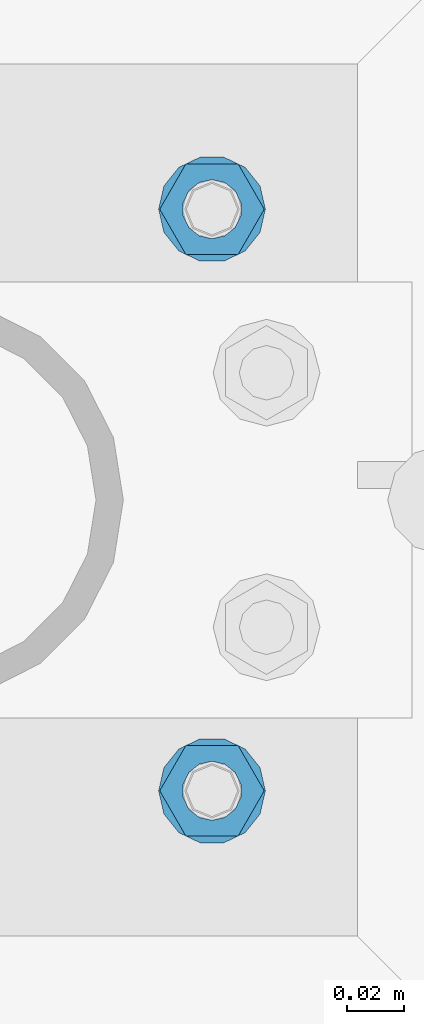
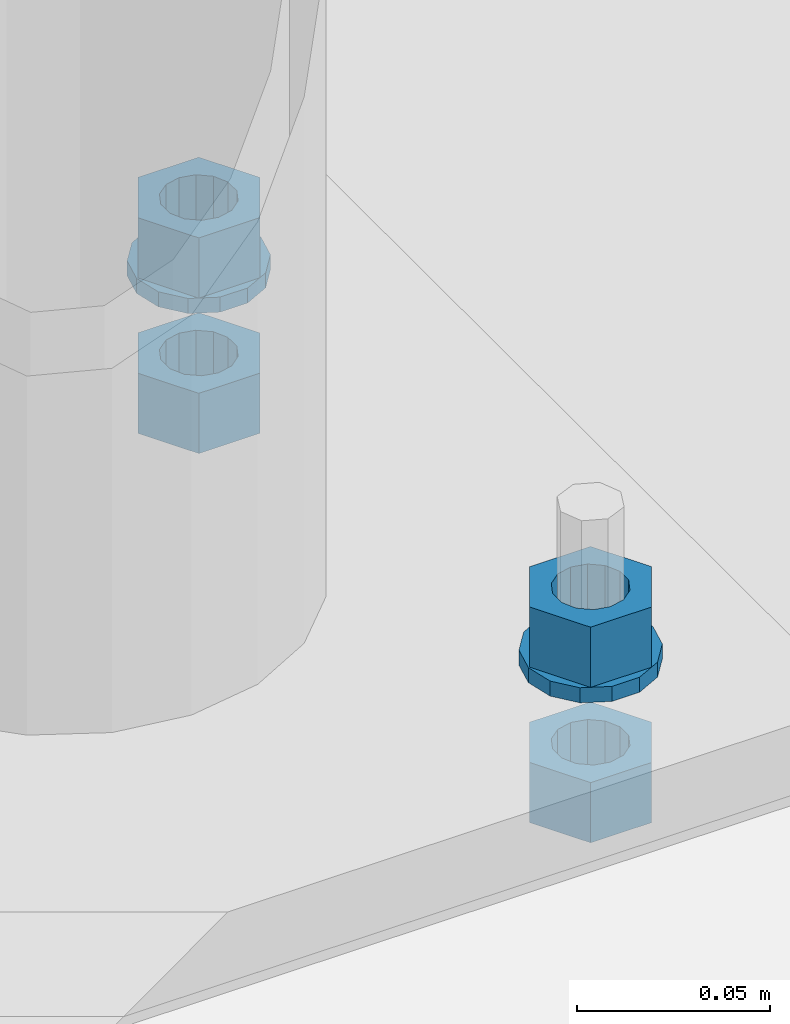
# One storey, part 585 of 975: 6 beams.
"""IFC2X3 building model written with IfcOpenShell, lengths in millimetres."""

from ifc_helpers import new_model, si_unit, frame, origin_with_axes, place, context, subcontext, project, spatial, faceted_brep, material, type_object, element, save


model = new_model("IFC2X3")

# Units and contexts
model_context = context("Model", 3, precision=1e-05, world=origin_with_axes())
body_context = subcontext(model_context, "Body", "Model", "MODEL_VIEW")
ifc_project = project(units=[si_unit("LENGTHUNIT", "METRE", prefix="MILLI"), si_unit("AREAUNIT", "SQUARE_METRE"), si_unit("VOLUMEUNIT", "CUBIC_METRE"), si_unit("MASSUNIT", "GRAM", prefix="KILO"), si_unit("TIMEUNIT", "SECOND"), si_unit("PLANEANGLEUNIT", "RADIAN"), si_unit("SOLIDANGLEUNIT", "STERADIAN"), si_unit("THERMODYNAMICTEMPERATUREUNIT", "DEGREE_CELSIUS"), si_unit("LUMINOUSINTENSITYUNIT", "LUMEN")], contexts=[model_context])

# Site, building, storey
site_placement = place(None, origin_with_axes())
site = spatial("IfcSite", under=ifc_project, at=site_placement, CompositionType="ELEMENT")
building_placement = place(site_placement, origin_with_axes())
building = spatial("IfcBuilding", under=site, at=building_placement, Name="Undefined", CompositionType="ELEMENT")
storey_placement = place(building_placement, origin_with_axes())
storey = spatial("IfcBuildingStorey", under=building, at=storey_placement, Name="Undefined", CompositionType="ELEMENT", Elevation=0.0)

# Beams
ifc_material = material(Name="STEEL/A36")
beam_type_1 = type_object("IfcBeamType", Name="3/4_WASHER", PredefinedType="NOTDEFINED")
beam_1_placement = place(storey_placement, frame((24826.9124984741, 13290.5500030518, -236.537499999998), z_axis=(0.0, -1.0, 0.0), x_axis=(0.0, 0.0, -1.0)))
element("IfcBeam", 1, at=beam_1_placement, inside=storey, type_object=beam_type_1, material=ifc_material, Name="WASHER", ObjectType="3/4_WASHER", context=body_context, shape_type="Brep", body=[
    faceted_brep([(0.0, -18.6499996185303, 0.0), (0.0, -16.8030690426876, -8.09193156902904), (4.76250000000073, -16.8030690426876, -8.09193156902904), (4.76250000000073, -18.6499996185303, 0.0), (0.0, -11.6280845668225, -14.5811568497838), (4.76250000000073, -11.6280845668225, -14.5811568497838), (0.0, -4.15001533340001, -18.1824051902857), (4.76250000000073, -4.15001533340001, -18.1824051902857), (0.0, 4.15001533340001, -18.1824051902857), (4.76250000000073, 4.15001533340001, -18.1824051902857), (0.0, 11.6280845668234, -14.5811568497838), (4.76250000000073, 11.6280845668234, -14.5811568497838), (0.0, 16.8030690426876, -8.09193156902904), (4.76250000000073, 16.8030690426876, -8.09193156902904), (0.0, 18.6499996185303, 0.0), (4.76250000000073, 18.6499996185303, 0.0), (0.0, 16.8030690426876, 8.09193156902904), (4.76250000000073, 16.8030690426876, 8.09193156902904), (0.0, 11.6280845668225, 14.5811568497838), (4.76250000000073, 11.6280845668225, 14.5811568497838), (0.0, 4.15001533340001, 18.1824051902857), (4.76250000000073, 4.15001533340001, 18.1824051902857), (0.0, -4.15001533340001, 18.1824051902857), (4.76250000000073, -4.15001533340001, 18.1824051902857), (0.0, -11.6280845668234, 14.5811568497838), (4.76250000000073, -11.6280845668234, 14.5811568497838), (0.0, -16.8030690426876, 8.09193156902904), (4.76250000000073, -16.8030690426876, 8.09193156902904), (0.0, 0.0, 10.3199996948242), (0.0, 4.47768005528269, 9.29799844179911), (4.76250000000073, 4.47768005528269, 9.29799844179911), (4.76250000000073, 0.0, 10.3199996948242), (0.0, 8.06850066047446, 6.43441456490817), (4.76250000000073, 8.06850066047446, 6.43441456490817), (0.0, 10.0612557561917, 2.29641597052117), (4.76250000000073, 10.0612557561917, 2.29641597052117), (0.0, 10.0612557561917, -2.29641597052117), (4.76250000000073, 10.0612557561917, -2.29641597052117), (0.0, 8.06850066047446, -6.43441456490814), (4.76250000000073, 8.06850066047446, -6.43441456490814), (0.0, 4.47768005528269, -9.29799844179908), (4.76250000000073, 4.47768005528269, -9.29799844179908), (0.0, 0.0, -10.3199996948242), (4.76250000000073, 0.0, -10.3199996948242), (0.0, -4.47768005528269, -9.29799844179911), (4.76250000000073, -4.47768005528269, -9.29799844179911), (0.0, -8.06850066047446, -6.43441456490817), (4.76250000000073, -8.06850066047446, -6.43441456490817), (0.0, -10.0612557561917, -2.29641597052117), (4.76250000000073, -10.0612557561917, -2.29641597052117), (0.0, -10.0612557561917, 2.29641597052117), (4.76250000000073, -10.0612557561917, 2.29641597052117), (0.0, -8.06850066047446, 6.43441456490814), (4.76250000000073, -8.06850066047446, 6.43441456490814), (0.0, -4.47768005528269, 9.29799844179908), (4.76250000000073, -4.47768005528269, 9.29799844179908)], [[[0, 1, 2, 3]], [[1, 4, 5, 2]], [[4, 6, 7, 5]], [[6, 8, 9, 7]], [[8, 10, 11, 9]], [[10, 12, 13, 11]], [[12, 14, 15, 13]], [[14, 16, 17, 15]], [[16, 18, 19, 17]], [[18, 20, 21, 19]], [[20, 22, 23, 21]], [[22, 24, 25, 23]], [[24, 26, 27, 25]], [[26, 0, 3, 27]], [[28, 29, 30, 31]], [[29, 32, 33, 30]], [[32, 34, 35, 33]], [[34, 36, 37, 35]], [[36, 38, 39, 37]], [[38, 40, 41, 39]], [[40, 42, 43, 41]], [[42, 44, 45, 43]], [[44, 46, 47, 45]], [[46, 48, 49, 47]], [[48, 50, 51, 49]], [[50, 52, 53, 51]], [[52, 54, 55, 53]], [[54, 28, 31, 55]], [[5, 7, 9, 11, 13, 15, 17, 19, 21, 23, 25, 27, 3, 2], [33, 35, 37, 39, 41, 43, 45, 47, 49, 51, 53, 55, 31, 30]], [[26, 24, 22, 20, 18, 16, 14, 12, 10, 8, 6, 4, 1, 0], [54, 52, 50, 48, 46, 44, 42, 40, 38, 36, 34, 32, 29, 28]]]),
])
beam_2_placement = place(storey_placement, frame((24826.9124984741, 13493.75, -236.537499999998), z_axis=(0.0, -1.0, 0.0), x_axis=(0.0, 0.0, -1.0)))
element("IfcBeam", 2, at=beam_2_placement, inside=storey, type_object=beam_type_1, material=ifc_material, Name="WASHER", ObjectType="3/4_WASHER", context=body_context, shape_type="Brep", body=[
    faceted_brep([(0.0, -18.6499996185303, 0.0), (0.0, -16.8030690426876, -8.09193156902904), (4.76250000000073, -16.8030690426876, -8.09193156902904), (4.76250000000073, -18.6499996185303, 0.0), (0.0, -11.6280845668225, -14.5811568497838), (4.76250000000073, -11.6280845668225, -14.5811568497838), (0.0, -4.15001533340001, -18.1824051902857), (4.76250000000073, -4.15001533340001, -18.1824051902857), (0.0, 4.15001533340001, -18.1824051902857), (4.76250000000073, 4.15001533340001, -18.1824051902857), (0.0, 11.6280845668234, -14.5811568497838), (4.76250000000073, 11.6280845668234, -14.5811568497838), (0.0, 16.8030690426876, -8.09193156902904), (4.76250000000073, 16.8030690426876, -8.09193156902904), (0.0, 18.6499996185303, 0.0), (4.76250000000073, 18.6499996185303, 0.0), (0.0, 16.8030690426876, 8.09193156902904), (4.76250000000073, 16.8030690426876, 8.09193156902904), (0.0, 11.6280845668225, 14.5811568497838), (4.76250000000073, 11.6280845668225, 14.5811568497838), (0.0, 4.15001533340001, 18.1824051902857), (4.76250000000073, 4.15001533340001, 18.1824051902857), (0.0, -4.15001533340001, 18.1824051902857), (4.76250000000073, -4.15001533340001, 18.1824051902857), (0.0, -11.6280845668234, 14.5811568497838), (4.76250000000073, -11.6280845668234, 14.5811568497838), (0.0, -16.8030690426876, 8.09193156902904), (4.76250000000073, -16.8030690426876, 8.09193156902904), (0.0, 0.0, 10.3199996948242), (0.0, 4.47768005528269, 9.29799844179911), (4.76250000000073, 4.47768005528269, 9.29799844179911), (4.76250000000073, 0.0, 10.3199996948242), (0.0, 8.06850066047446, 6.43441456490817), (4.76250000000073, 8.06850066047446, 6.43441456490817), (0.0, 10.0612557561917, 2.29641597052117), (4.76250000000073, 10.0612557561917, 2.29641597052117), (0.0, 10.0612557561917, -2.29641597052117), (4.76250000000073, 10.0612557561917, -2.29641597052117), (0.0, 8.06850066047446, -6.43441456490814), (4.76250000000073, 8.06850066047446, -6.43441456490814), (0.0, 4.47768005528269, -9.29799844179908), (4.76250000000073, 4.47768005528269, -9.29799844179908), (0.0, 0.0, -10.3199996948242), (4.76250000000073, 0.0, -10.3199996948242), (0.0, -4.47768005528269, -9.29799844179911), (4.76250000000073, -4.47768005528269, -9.29799844179911), (0.0, -8.06850066047446, -6.43441456490817), (4.76250000000073, -8.06850066047446, -6.43441456490817), (0.0, -10.0612557561917, -2.29641597052117), (4.76250000000073, -10.0612557561917, -2.29641597052117), (0.0, -10.0612557561917, 2.29641597052117), (4.76250000000073, -10.0612557561917, 2.29641597052117), (0.0, -8.06850066047446, 6.43441456490814), (4.76250000000073, -8.06850066047446, 6.43441456490814), (0.0, -4.47768005528269, 9.29799844179908), (4.76250000000073, -4.47768005528269, 9.29799844179908)], [[[0, 1, 2, 3]], [[1, 4, 5, 2]], [[4, 6, 7, 5]], [[6, 8, 9, 7]], [[8, 10, 11, 9]], [[10, 12, 13, 11]], [[12, 14, 15, 13]], [[14, 16, 17, 15]], [[16, 18, 19, 17]], [[18, 20, 21, 19]], [[20, 22, 23, 21]], [[22, 24, 25, 23]], [[24, 26, 27, 25]], [[26, 0, 3, 27]], [[28, 29, 30, 31]], [[29, 32, 33, 30]], [[32, 34, 35, 33]], [[34, 36, 37, 35]], [[36, 38, 39, 37]], [[38, 40, 41, 39]], [[40, 42, 43, 41]], [[42, 44, 45, 43]], [[44, 46, 47, 45]], [[46, 48, 49, 47]], [[48, 50, 51, 49]], [[50, 52, 53, 51]], [[52, 54, 55, 53]], [[54, 28, 31, 55]], [[5, 7, 9, 11, 13, 15, 17, 19, 21, 23, 25, 27, 3, 2], [33, 35, 37, 39, 41, 43, 45, 47, 49, 51, 53, 55, 31, 30]], [[26, 24, 22, 20, 18, 16, 14, 12, 10, 8, 6, 4, 1, 0], [54, 52, 50, 48, 46, 44, 42, 40, 38, 36, 34, 32, 29, 28]]]),
])
beam_type_2 = type_object("IfcBeamType", Name="3/4_HEAVY_HEX_NUT", PredefinedType="NOTDEFINED")
beam_3_placement = place(storey_placement, frame((24826.9124984741, 13290.5500030518, -217.487499999999), z_axis=(0.0, -1.0, 0.0), x_axis=(0.0, 0.0, -1.0)))
element("IfcBeam", 3, at=beam_3_placement, inside=storey, type_object=beam_type_2, material=ifc_material, Name="NUT", ObjectType="3/4_HEAVY_HEX_NUT", context=body_context, shape_type="Brep", body=[
    faceted_brep([(0.0, -18.2600002288818, 0.0), (0.0, -9.13000011444092, -15.8100004196167), (19.0499999999993, -9.13000011444092, -15.8100004196167), (19.0499999999993, -18.2600002288818, 0.0), (0.0, 9.13000011444092, -15.8100004196167), (19.0499999999993, 9.13000011444092, -15.8100004196167), (0.0, 18.2600002288818, 0.0), (19.0499999999993, 18.2600002288818, 0.0), (0.0, 9.13000011444092, 15.8100004196167), (19.0499999999993, 9.13000011444092, 15.8100004196167), (0.0, -9.13000011444092, 15.8100004196167), (19.0499999999993, -9.13000011444092, 15.8100004196167), (0.0, 0.0, 10.3199996948242), (0.0, 4.47768005528269, 9.29799844179911), (19.0499999999993, 4.47768005528269, 9.29799844179911), (19.0499999999993, 0.0, 10.3199996948242), (0.0, 8.06850066047446, 6.43441456490817), (19.0499999999993, 8.06850066047446, 6.43441456490817), (0.0, 10.0612557561917, 2.29641597052117), (19.0499999999993, 10.0612557561917, 2.29641597052117), (0.0, 10.0612557561917, -2.29641597052117), (19.0499999999993, 10.0612557561917, -2.29641597052117), (0.0, 8.06850066047446, -6.43441456490814), (19.0499999999993, 8.06850066047446, -6.43441456490814), (0.0, 4.47768005528269, -9.29799844179908), (19.0499999999993, 4.47768005528269, -9.29799844179908), (0.0, 0.0, -10.3199996948242), (19.0499999999993, 0.0, -10.3199996948242), (0.0, -4.47768005528269, -9.29799844179911), (19.0499999999993, -4.47768005528269, -9.29799844179911), (0.0, -8.06850066047446, -6.43441456490817), (19.0499999999993, -8.06850066047446, -6.43441456490817), (0.0, -10.0612557561917, -2.29641597052117), (19.0499999999993, -10.0612557561917, -2.29641597052117), (0.0, -10.0612557561917, 2.29641597052117), (19.0499999999993, -10.0612557561917, 2.29641597052117), (0.0, -8.06850066047446, 6.43441456490814), (19.0499999999993, -8.06850066047446, 6.43441456490814), (0.0, -4.47768005528269, 9.29799844179908), (19.0499999999993, -4.47768005528269, 9.29799844179908)], [[[0, 1, 2, 3]], [[1, 4, 5, 2]], [[4, 6, 7, 5]], [[6, 8, 9, 7]], [[8, 10, 11, 9]], [[10, 0, 3, 11]], [[12, 13, 14, 15]], [[13, 16, 17, 14]], [[16, 18, 19, 17]], [[18, 20, 21, 19]], [[20, 22, 23, 21]], [[22, 24, 25, 23]], [[24, 26, 27, 25]], [[26, 28, 29, 27]], [[28, 30, 31, 29]], [[30, 32, 33, 31]], [[32, 34, 35, 33]], [[34, 36, 37, 35]], [[36, 38, 39, 37]], [[38, 12, 15, 39]], [[5, 7, 9, 11, 3, 2], [17, 19, 21, 23, 25, 27, 29, 31, 33, 35, 37, 39, 15, 14]], [[10, 8, 6, 4, 1, 0], [38, 36, 34, 32, 30, 28, 26, 24, 22, 20, 18, 16, 13, 12]]]),
])
beam_4_placement = place(storey_placement, frame((24826.9124984741, 13493.75, -217.487499999999), z_axis=(0.0, -1.0, 0.0), x_axis=(0.0, 0.0, -1.0)))
element("IfcBeam", 4, at=beam_4_placement, inside=storey, type_object=beam_type_2, material=ifc_material, Name="NUT", ObjectType="3/4_HEAVY_HEX_NUT", context=body_context, shape_type="Brep", body=[
    faceted_brep([(0.0, -18.2600002288818, 0.0), (0.0, -9.13000011444092, -15.8100004196167), (19.0499999999993, -9.13000011444092, -15.8100004196167), (19.0499999999993, -18.2600002288818, 0.0), (0.0, 9.13000011444092, -15.8100004196167), (19.0499999999993, 9.13000011444092, -15.8100004196167), (0.0, 18.2600002288818, 0.0), (19.0499999999993, 18.2600002288818, 0.0), (0.0, 9.13000011444092, 15.8100004196167), (19.0499999999993, 9.13000011444092, 15.8100004196167), (0.0, -9.13000011444092, 15.8100004196167), (19.0499999999993, -9.13000011444092, 15.8100004196167), (0.0, 0.0, 10.3199996948242), (0.0, 4.47768005528269, 9.29799844179911), (19.0499999999993, 4.47768005528269, 9.29799844179911), (19.0499999999993, 0.0, 10.3199996948242), (0.0, 8.06850066047446, 6.43441456490817), (19.0499999999993, 8.06850066047446, 6.43441456490817), (0.0, 10.0612557561917, 2.29641597052117), (19.0499999999993, 10.0612557561917, 2.29641597052117), (0.0, 10.0612557561917, -2.29641597052117), (19.0499999999993, 10.0612557561917, -2.29641597052117), (0.0, 8.06850066047446, -6.43441456490814), (19.0499999999993, 8.06850066047446, -6.43441456490814), (0.0, 4.47768005528269, -9.29799844179908), (19.0499999999993, 4.47768005528269, -9.29799844179908), (0.0, 0.0, -10.3199996948242), (19.0499999999993, 0.0, -10.3199996948242), (0.0, -4.47768005528269, -9.29799844179911), (19.0499999999993, -4.47768005528269, -9.29799844179911), (0.0, -8.06850066047446, -6.43441456490817), (19.0499999999993, -8.06850066047446, -6.43441456490817), (0.0, -10.0612557561917, -2.29641597052117), (19.0499999999993, -10.0612557561917, -2.29641597052117), (0.0, -10.0612557561917, 2.29641597052117), (19.0499999999993, -10.0612557561917, 2.29641597052117), (0.0, -8.06850066047446, 6.43441456490814), (19.0499999999993, -8.06850066047446, 6.43441456490814), (0.0, -4.47768005528269, 9.29799844179908), (19.0499999999993, -4.47768005528269, 9.29799844179908)], [[[0, 1, 2, 3]], [[1, 4, 5, 2]], [[4, 6, 7, 5]], [[6, 8, 9, 7]], [[8, 10, 11, 9]], [[10, 0, 3, 11]], [[12, 13, 14, 15]], [[13, 16, 17, 14]], [[16, 18, 19, 17]], [[18, 20, 21, 19]], [[20, 22, 23, 21]], [[22, 24, 25, 23]], [[24, 26, 27, 25]], [[26, 28, 29, 27]], [[28, 30, 31, 29]], [[30, 32, 33, 31]], [[32, 34, 35, 33]], [[34, 36, 37, 35]], [[36, 38, 39, 37]], [[38, 12, 15, 39]], [[5, 7, 9, 11, 3, 2], [17, 19, 21, 23, 25, 27, 29, 31, 33, 35, 37, 39, 15, 14]], [[10, 8, 6, 4, 1, 0], [38, 36, 34, 32, 30, 28, 26, 24, 22, 20, 18, 16, 13, 12]]]),
])
beam_5_placement = place(storey_placement, frame((24826.9124984741, 13290.5500030518, -266.7), z_axis=(0.0, -1.0, 0.0), x_axis=(0.0, 0.0, -1.0)))
element("IfcBeam", 5, at=beam_5_placement, inside=storey, type_object=beam_type_2, material=ifc_material, Name="NUT", ObjectType="3/4_HEAVY_HEX_NUT", context=body_context, shape_type="Brep", body=[
    faceted_brep([(0.0, -18.2600002288818, 0.0), (0.0, -9.13000011444092, -15.8100004196167), (19.0499999999993, -9.13000011444092, -15.8100004196167), (19.0499999999993, -18.2600002288818, 0.0), (0.0, 9.13000011444092, -15.8100004196167), (19.0499999999993, 9.13000011444092, -15.8100004196167), (0.0, 18.2600002288818, 0.0), (19.0499999999993, 18.2600002288818, 0.0), (0.0, 9.13000011444092, 15.8100004196167), (19.0499999999993, 9.13000011444092, 15.8100004196167), (0.0, -9.13000011444092, 15.8100004196167), (19.0499999999993, -9.13000011444092, 15.8100004196167), (0.0, 0.0, 10.3199996948242), (0.0, 4.47768005528269, 9.29799844179911), (19.0499999999993, 4.47768005528269, 9.29799844179911), (19.0499999999993, 0.0, 10.3199996948242), (0.0, 8.06850066047446, 6.43441456490817), (19.0499999999993, 8.06850066047446, 6.43441456490817), (0.0, 10.0612557561917, 2.29641597052117), (19.0499999999993, 10.0612557561917, 2.29641597052117), (0.0, 10.0612557561917, -2.29641597052117), (19.0499999999993, 10.0612557561917, -2.29641597052117), (0.0, 8.06850066047446, -6.43441456490814), (19.0499999999993, 8.06850066047446, -6.43441456490814), (0.0, 4.47768005528269, -9.29799844179908), (19.0499999999993, 4.47768005528269, -9.29799844179908), (0.0, 0.0, -10.3199996948242), (19.0499999999993, 0.0, -10.3199996948242), (0.0, -4.47768005528269, -9.29799844179911), (19.0499999999993, -4.47768005528269, -9.29799844179911), (0.0, -8.06850066047446, -6.43441456490817), (19.0499999999993, -8.06850066047446, -6.43441456490817), (0.0, -10.0612557561917, -2.29641597052117), (19.0499999999993, -10.0612557561917, -2.29641597052117), (0.0, -10.0612557561917, 2.29641597052117), (19.0499999999993, -10.0612557561917, 2.29641597052117), (0.0, -8.06850066047446, 6.43441456490814), (19.0499999999993, -8.06850066047446, 6.43441456490814), (0.0, -4.47768005528269, 9.29799844179908), (19.0499999999993, -4.47768005528269, 9.29799844179908)], [[[0, 1, 2, 3]], [[1, 4, 5, 2]], [[4, 6, 7, 5]], [[6, 8, 9, 7]], [[8, 10, 11, 9]], [[10, 0, 3, 11]], [[12, 13, 14, 15]], [[13, 16, 17, 14]], [[16, 18, 19, 17]], [[18, 20, 21, 19]], [[20, 22, 23, 21]], [[22, 24, 25, 23]], [[24, 26, 27, 25]], [[26, 28, 29, 27]], [[28, 30, 31, 29]], [[30, 32, 33, 31]], [[32, 34, 35, 33]], [[34, 36, 37, 35]], [[36, 38, 39, 37]], [[38, 12, 15, 39]], [[5, 7, 9, 11, 3, 2], [17, 19, 21, 23, 25, 27, 29, 31, 33, 35, 37, 39, 15, 14]], [[10, 8, 6, 4, 1, 0], [38, 36, 34, 32, 30, 28, 26, 24, 22, 20, 18, 16, 13, 12]]]),
])
beam_6_placement = place(storey_placement, frame((24826.9124984741, 13493.75, -266.7), z_axis=(0.0, -1.0, 0.0), x_axis=(0.0, 0.0, -1.0)))
element("IfcBeam", 6, at=beam_6_placement, inside=storey, type_object=beam_type_2, material=ifc_material, Name="NUT", ObjectType="3/4_HEAVY_HEX_NUT", context=body_context, shape_type="Brep", body=[
    faceted_brep([(0.0, -18.2600002288818, 0.0), (0.0, -9.13000011444092, -15.8100004196167), (19.0499999999993, -9.13000011444092, -15.8100004196167), (19.0499999999993, -18.2600002288818, 0.0), (0.0, 9.13000011444092, -15.8100004196167), (19.0499999999993, 9.13000011444092, -15.8100004196167), (0.0, 18.2600002288818, 0.0), (19.0499999999993, 18.2600002288818, 0.0), (0.0, 9.13000011444092, 15.8100004196167), (19.0499999999993, 9.13000011444092, 15.8100004196167), (0.0, -9.13000011444092, 15.8100004196167), (19.0499999999993, -9.13000011444092, 15.8100004196167), (0.0, 0.0, 10.3199996948242), (0.0, 4.47768005528269, 9.29799844179911), (19.0499999999993, 4.47768005528269, 9.29799844179911), (19.0499999999993, 0.0, 10.3199996948242), (0.0, 8.06850066047446, 6.43441456490817), (19.0499999999993, 8.06850066047446, 6.43441456490817), (0.0, 10.0612557561917, 2.29641597052117), (19.0499999999993, 10.0612557561917, 2.29641597052117), (0.0, 10.0612557561917, -2.29641597052117), (19.0499999999993, 10.0612557561917, -2.29641597052117), (0.0, 8.06850066047446, -6.43441456490814), (19.0499999999993, 8.06850066047446, -6.43441456490814), (0.0, 4.47768005528269, -9.29799844179908), (19.0499999999993, 4.47768005528269, -9.29799844179908), (0.0, 0.0, -10.3199996948242), (19.0499999999993, 0.0, -10.3199996948242), (0.0, -4.47768005528269, -9.29799844179911), (19.0499999999993, -4.47768005528269, -9.29799844179911), (0.0, -8.06850066047446, -6.43441456490817), (19.0499999999993, -8.06850066047446, -6.43441456490817), (0.0, -10.0612557561917, -2.29641597052117), (19.0499999999993, -10.0612557561917, -2.29641597052117), (0.0, -10.0612557561917, 2.29641597052117), (19.0499999999993, -10.0612557561917, 2.29641597052117), (0.0, -8.06850066047446, 6.43441456490814), (19.0499999999993, -8.06850066047446, 6.43441456490814), (0.0, -4.47768005528269, 9.29799844179908), (19.0499999999993, -4.47768005528269, 9.29799844179908)], [[[0, 1, 2, 3]], [[1, 4, 5, 2]], [[4, 6, 7, 5]], [[6, 8, 9, 7]], [[8, 10, 11, 9]], [[10, 0, 3, 11]], [[12, 13, 14, 15]], [[13, 16, 17, 14]], [[16, 18, 19, 17]], [[18, 20, 21, 19]], [[20, 22, 23, 21]], [[22, 24, 25, 23]], [[24, 26, 27, 25]], [[26, 28, 29, 27]], [[28, 30, 31, 29]], [[30, 32, 33, 31]], [[32, 34, 35, 33]], [[34, 36, 37, 35]], [[36, 38, 39, 37]], [[38, 12, 15, 39]], [[5, 7, 9, 11, 3, 2], [17, 19, 21, 23, 25, 27, 29, 31, 33, 35, 37, 39, 15, 14]], [[10, 8, 6, 4, 1, 0], [38, 36, 34, 32, 30, 28, 26, 24, 22, 20, 18, 16, 13, 12]]]),
])

save(model, "model.ifc")
